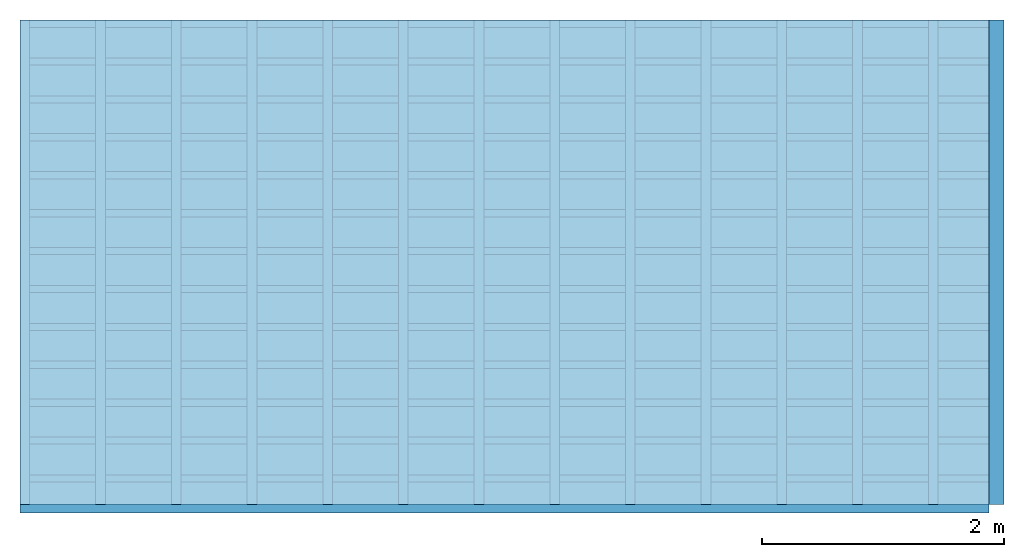
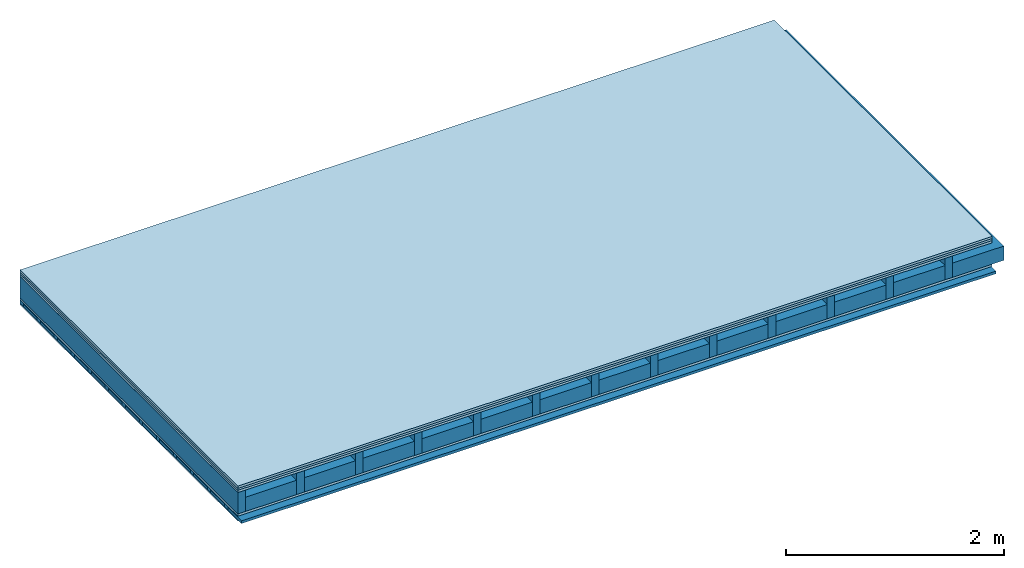
# One storey: 5 plates, 4 members, 1 element without a shape of its own.
"""IFC4 building model written with IfcOpenShell, lengths in metres."""

from ifc_helpers import new_model, si_unit, derived_unit, direction, frame, frame_2d, origin, origin_with_axes, place, context, project, spatial, rectangle, extrude, material, layer, layer_set, type_object, element, aggregate, save


model = new_model("IFC4")

# Units and contexts
plan_context = context("Plan", 3, precision=1e-05, world=origin(), true_north=direction((0.0, 1.0)))
model_context = context("Model", 3, precision=1e-05, world=origin(), true_north=direction((0.0, 1.0)))
ifc_project = project(units=[si_unit("LENGTHUNIT", "METRE"), derived_unit("SOUNDPRESSUREUNIT", [(si_unit("PRESSUREUNIT", "PASCAL", prefix="MICRO"), 0)]), si_unit("ENERGYUNIT", "JOULE", prefix="MEGA"), si_unit("MASSUNIT", "GRAM", prefix="KILO"), derived_unit("THERMALTRANSMITTANCEUNIT", [(si_unit("POWERUNIT", "WATT"), 1), (si_unit("AREAUNIT", "SQUARE_METRE"), -1), (si_unit("THERMODYNAMICTEMPERATUREUNIT", "KELVIN"), -1)]), derived_unit("AREADENSITYUNIT", [(si_unit("MASSUNIT", "GRAM", prefix="KILO"), 1), (si_unit("AREAUNIT", "SQUARE_METRE"), -1)]), derived_unit("USERDEFINED", [(si_unit("ENERGYUNIT", "JOULE", prefix="MEGA"), 1), (si_unit("AREAUNIT", "SQUARE_METRE"), -1)])], contexts=[plan_context, model_context])

# Site, building, storey
site = spatial("IfcSite", under=ifc_project)
building_placement = place(None, origin())
building = spatial("IfcBuilding", under=site, at=building_placement)
storey_placement = place(building_placement, origin())
storey = spatial("IfcBuildingStorey", under=building, at=storey_placement)

# Slab, members, plates
ifc_material_1 = material(Name="Floor heating system Therm38 longitudinal", Category="03.007")
ifc_layer_1 = layer(ifc_material_1, 0.025, Name="On-material")
ifc_material_2 = material(Category="10.009")
ifc_layer_2 = layer(ifc_material_2, 0.022, Name="Impact sound insulation")
ifc_material_3 = material(Category="07.001")
ifc_layer_3 = layer(ifc_material_3, 0.025, Name="Sub-floor")
ifc_material_4 = material(Name="Rigid, of the art")
ifc_layer_4 = layer(ifc_material_4, 0.0, Name="Bond")
ifc_layer_5 = layer(None, 0.24, Name="Supporting structure")
ifc_layer_6 = layer(ifc_material_4, 0.0, Name="Bond")
ifc_layer_7 = layer(ifc_material_3, 0.025, Name="Lower layer 1")
ifc_layer_8 = layer(None, 0.04, Name="Battens / profiles")
ifc_material_5 = material(Category="03.007")
ifc_layer_9 = layer(ifc_material_5, 0.015, Name="Ceiling covering 1st layer")
ifc_material_6 = material(Name="Glued joints")
ifc_layer_10 = layer(ifc_material_6, 0.0, Name="Surface / treatment")
ifc_layer_set = layer_set([ifc_layer_1, ifc_layer_2, ifc_layer_3, ifc_layer_4, ifc_layer_5, ifc_layer_6, ifc_layer_7, ifc_layer_8, ifc_layer_9, ifc_layer_10])
slab_type = type_object("IfcSlabType", Name="A0307", PredefinedType="NOTDEFINED", material=ifc_layer_set)
slab_placement = place(None, frame((0.0, 0.0, 0.0), z_axis=(0.0, 0.0, -1.0), x_axis=(1.0, 0.0, 0.0)))
slab = element("IfcSlab", 1, at=slab_placement, inside=storey, type_object=slab_type, material=ifc_layer_set, Name="Slab #1")
ifc_material_7 = material()
member_1_placement = place(slab_placement, origin())
member_1 = element("IfcMember", 2, at=member_1_placement, material=ifc_material_7, Name="Supporting structure", context=plan_context, shape_type="SweptSolid", body=[
    extrude(rectangle(XDim=0.08, YDim=0.24, at=frame_2d((0.04, 0.12), x_axis=(1.0, 0.0))), frame((0.0, 4.0, 0.072), z_axis=(0.0, -1.0, 0.0), x_axis=(1.0, 0.0, 0.0)), (0.0, 0.0, 1.0), 4.0),
    extrude(rectangle(XDim=0.08, YDim=0.24, at=frame_2d((0.04, 0.12), x_axis=(1.0, 0.0))), frame((0.625, 4.0, 0.072), z_axis=(0.0, -1.0, 0.0), x_axis=(1.0, 0.0, 0.0)), (0.0, 0.0, 1.0), 4.0),
    extrude(rectangle(XDim=0.08, YDim=0.24, at=frame_2d((0.04, 0.12), x_axis=(1.0, 0.0))), frame((1.25, 4.0, 0.072), z_axis=(0.0, -1.0, 0.0), x_axis=(1.0, 0.0, 0.0)), (0.0, 0.0, 1.0), 4.0),
    extrude(rectangle(XDim=0.08, YDim=0.24, at=frame_2d((0.04, 0.12), x_axis=(1.0, 0.0))), frame((1.875, 4.0, 0.072), z_axis=(0.0, -1.0, 0.0), x_axis=(1.0, 0.0, 0.0)), (0.0, 0.0, 1.0), 4.0),
    extrude(rectangle(XDim=0.08, YDim=0.24, at=frame_2d((0.04, 0.12), x_axis=(1.0, 0.0))), frame((2.5, 4.0, 0.072), z_axis=(0.0, -1.0, 0.0), x_axis=(1.0, 0.0, 0.0)), (0.0, 0.0, 1.0), 4.0),
    extrude(rectangle(XDim=0.08, YDim=0.24, at=frame_2d((0.04, 0.12), x_axis=(1.0, 0.0))), frame((3.125, 4.0, 0.072), z_axis=(0.0, -1.0, 0.0), x_axis=(1.0, 0.0, 0.0)), (0.0, 0.0, 1.0), 4.0),
    extrude(rectangle(XDim=0.08, YDim=0.24, at=frame_2d((0.04, 0.12), x_axis=(1.0, 0.0))), frame((3.75, 4.0, 0.072), z_axis=(0.0, -1.0, 0.0), x_axis=(1.0, 0.0, 0.0)), (0.0, 0.0, 1.0), 4.0),
    extrude(rectangle(XDim=0.08, YDim=0.24, at=frame_2d((0.04, 0.12), x_axis=(1.0, 0.0))), frame((4.375, 4.0, 0.072), z_axis=(0.0, -1.0, 0.0), x_axis=(1.0, 0.0, 0.0)), (0.0, 0.0, 1.0), 4.0),
    extrude(rectangle(XDim=0.08, YDim=0.24, at=frame_2d((0.04, 0.12), x_axis=(1.0, 0.0))), frame((5.0, 4.0, 0.072), z_axis=(0.0, -1.0, 0.0), x_axis=(1.0, 0.0, 0.0)), (0.0, 0.0, 1.0), 4.0),
    extrude(rectangle(XDim=0.08, YDim=0.24, at=frame_2d((0.04, 0.12), x_axis=(1.0, 0.0))), frame((5.625, 4.0, 0.072), z_axis=(0.0, -1.0, 0.0), x_axis=(1.0, 0.0, 0.0)), (0.0, 0.0, 1.0), 4.0),
    extrude(rectangle(XDim=0.08, YDim=0.24, at=frame_2d((0.04, 0.12), x_axis=(1.0, 0.0))), frame((6.25, 4.0, 0.072), z_axis=(0.0, -1.0, 0.0), x_axis=(1.0, 0.0, 0.0)), (0.0, 0.0, 1.0), 4.0),
    extrude(rectangle(XDim=0.08, YDim=0.24, at=frame_2d((0.04, 0.12), x_axis=(1.0, 0.0))), frame((6.875, 4.0, 0.072), z_axis=(0.0, -1.0, 0.0), x_axis=(1.0, 0.0, 0.0)), (0.0, 0.0, 1.0), 4.0),
    extrude(rectangle(XDim=0.08, YDim=0.24, at=frame_2d((0.04, 0.12), x_axis=(1.0, 0.0))), frame((7.5, 4.0, 0.072), z_axis=(0.0, -1.0, 0.0), x_axis=(1.0, 0.0, 0.0)), (0.0, 0.0, 1.0), 4.0),
])
ifc_material_8 = material()
member_2_placement = place(slab_placement, origin())
member_2 = element("IfcMember", 3, at=member_2_placement, material=ifc_material_8, Name="Cavity", context=plan_context, shape_type="SweptSolid", body=[
    extrude(rectangle(XDim=0.545, YDim=0.16, at=frame_2d((0.2725, 0.08), x_axis=(1.0, 0.0))), frame((0.08, 4.0, 0.152), z_axis=(0.0, -1.0, 0.0), x_axis=(1.0, 0.0, 0.0)), (0.0, 0.0, 1.0), 4.0),
    extrude(rectangle(XDim=0.545, YDim=0.16, at=frame_2d((0.2725, 0.08), x_axis=(1.0, 0.0))), frame((0.705, 4.0, 0.152), z_axis=(0.0, -1.0, 0.0), x_axis=(1.0, 0.0, 0.0)), (0.0, 0.0, 1.0), 4.0),
    extrude(rectangle(XDim=0.545, YDim=0.16, at=frame_2d((0.2725, 0.08), x_axis=(1.0, 0.0))), frame((1.33, 4.0, 0.152), z_axis=(0.0, -1.0, 0.0), x_axis=(1.0, 0.0, 0.0)), (0.0, 0.0, 1.0), 4.0),
    extrude(rectangle(XDim=0.545, YDim=0.16, at=frame_2d((0.2725, 0.08), x_axis=(1.0, 0.0))), frame((1.955, 4.0, 0.152), z_axis=(0.0, -1.0, 0.0), x_axis=(1.0, 0.0, 0.0)), (0.0, 0.0, 1.0), 4.0),
    extrude(rectangle(XDim=0.545, YDim=0.16, at=frame_2d((0.2725, 0.08), x_axis=(1.0, 0.0))), frame((2.58, 4.0, 0.152), z_axis=(0.0, -1.0, 0.0), x_axis=(1.0, 0.0, 0.0)), (0.0, 0.0, 1.0), 4.0),
    extrude(rectangle(XDim=0.545, YDim=0.16, at=frame_2d((0.2725, 0.08), x_axis=(1.0, 0.0))), frame((3.205, 4.0, 0.152), z_axis=(0.0, -1.0, 0.0), x_axis=(1.0, 0.0, 0.0)), (0.0, 0.0, 1.0), 4.0),
    extrude(rectangle(XDim=0.545, YDim=0.16, at=frame_2d((0.2725, 0.08), x_axis=(1.0, 0.0))), frame((3.83, 4.0, 0.152), z_axis=(0.0, -1.0, 0.0), x_axis=(1.0, 0.0, 0.0)), (0.0, 0.0, 1.0), 4.0),
    extrude(rectangle(XDim=0.545, YDim=0.16, at=frame_2d((0.2725, 0.08), x_axis=(1.0, 0.0))), frame((4.455, 4.0, 0.152), z_axis=(0.0, -1.0, 0.0), x_axis=(1.0, 0.0, 0.0)), (0.0, 0.0, 1.0), 4.0),
    extrude(rectangle(XDim=0.545, YDim=0.16, at=frame_2d((0.2725, 0.08), x_axis=(1.0, 0.0))), frame((5.08, 4.0, 0.152), z_axis=(0.0, -1.0, 0.0), x_axis=(1.0, 0.0, 0.0)), (0.0, 0.0, 1.0), 4.0),
    extrude(rectangle(XDim=0.545, YDim=0.16, at=frame_2d((0.2725, 0.08), x_axis=(1.0, 0.0))), frame((5.705, 4.0, 0.152), z_axis=(0.0, -1.0, 0.0), x_axis=(1.0, 0.0, 0.0)), (0.0, 0.0, 1.0), 4.0),
    extrude(rectangle(XDim=0.545, YDim=0.16, at=frame_2d((0.2725, 0.08), x_axis=(1.0, 0.0))), frame((6.33, 4.0, 0.152), z_axis=(0.0, -1.0, 0.0), x_axis=(1.0, 0.0, 0.0)), (0.0, 0.0, 1.0), 4.0),
    extrude(rectangle(XDim=0.545, YDim=0.16, at=frame_2d((0.2725, 0.08), x_axis=(1.0, 0.0))), frame((6.955, 4.0, 0.152), z_axis=(0.0, -1.0, 0.0), x_axis=(1.0, 0.0, 0.0)), (0.0, 0.0, 1.0), 4.0),
    extrude(rectangle(XDim=0.545, YDim=0.16, at=frame_2d((0.2725, 0.08), x_axis=(1.0, 0.0))), frame((7.58, 4.0, 0.152), z_axis=(0.0, -1.0, 0.0), x_axis=(1.0, 0.0, 0.0)), (0.0, 0.0, 1.0), 4.0),
])
ifc_material_9 = material()
member_3_placement = place(slab_placement, origin())
member_3 = element("IfcMember", 4, at=member_3_placement, material=ifc_material_9, Name="Battens / profiles", context=plan_context, shape_type="SweptSolid", body=[
    extrude(rectangle(XDim=0.06, YDim=0.04, at=frame_2d((0.03, 0.02), x_axis=(1.0, 0.0))), frame((0.0, 0.0, 0.337), z_axis=(1.0, 0.0, 0.0), x_axis=(0.0, 1.0, 0.0)), (0.0, 0.0, 1.0), 8.0),
    extrude(rectangle(XDim=0.06, YDim=0.04, at=frame_2d((0.03, 0.02), x_axis=(1.0, 0.0))), frame((0.0, 0.313, 0.337), z_axis=(1.0, 0.0, 0.0), x_axis=(0.0, 1.0, 0.0)), (0.0, 0.0, 1.0), 8.0),
    extrude(rectangle(XDim=0.06, YDim=0.04, at=frame_2d((0.03, 0.02), x_axis=(1.0, 0.0))), frame((0.0, 0.626, 0.337), z_axis=(1.0, 0.0, 0.0), x_axis=(0.0, 1.0, 0.0)), (0.0, 0.0, 1.0), 8.0),
    extrude(rectangle(XDim=0.06, YDim=0.04, at=frame_2d((0.03, 0.02), x_axis=(1.0, 0.0))), frame((0.0, 0.939, 0.337), z_axis=(1.0, 0.0, 0.0), x_axis=(0.0, 1.0, 0.0)), (0.0, 0.0, 1.0), 8.0),
    extrude(rectangle(XDim=0.06, YDim=0.04, at=frame_2d((0.03, 0.02), x_axis=(1.0, 0.0))), frame((0.0, 1.252, 0.337), z_axis=(1.0, 0.0, 0.0), x_axis=(0.0, 1.0, 0.0)), (0.0, 0.0, 1.0), 8.0),
    extrude(rectangle(XDim=0.06, YDim=0.04, at=frame_2d((0.03, 0.02), x_axis=(1.0, 0.0))), frame((0.0, 1.565, 0.337), z_axis=(1.0, 0.0, 0.0), x_axis=(0.0, 1.0, 0.0)), (0.0, 0.0, 1.0), 8.0),
    extrude(rectangle(XDim=0.06, YDim=0.04, at=frame_2d((0.03, 0.02), x_axis=(1.0, 0.0))), frame((0.0, 1.878, 0.337), z_axis=(1.0, 0.0, 0.0), x_axis=(0.0, 1.0, 0.0)), (0.0, 0.0, 1.0), 8.0),
    extrude(rectangle(XDim=0.06, YDim=0.04, at=frame_2d((0.03, 0.02), x_axis=(1.0, 0.0))), frame((0.0, 2.191, 0.337), z_axis=(1.0, 0.0, 0.0), x_axis=(0.0, 1.0, 0.0)), (0.0, 0.0, 1.0), 8.0),
    extrude(rectangle(XDim=0.06, YDim=0.04, at=frame_2d((0.03, 0.02), x_axis=(1.0, 0.0))), frame((0.0, 2.504, 0.337), z_axis=(1.0, 0.0, 0.0), x_axis=(0.0, 1.0, 0.0)), (0.0, 0.0, 1.0), 8.0),
    extrude(rectangle(XDim=0.06, YDim=0.04, at=frame_2d((0.03, 0.02), x_axis=(1.0, 0.0))), frame((0.0, 2.817, 0.337), z_axis=(1.0, 0.0, 0.0), x_axis=(0.0, 1.0, 0.0)), (0.0, 0.0, 1.0), 8.0),
    extrude(rectangle(XDim=0.06, YDim=0.04, at=frame_2d((0.03, 0.02), x_axis=(1.0, 0.0))), frame((0.0, 3.13, 0.337), z_axis=(1.0, 0.0, 0.0), x_axis=(0.0, 1.0, 0.0)), (0.0, 0.0, 1.0), 8.0),
    extrude(rectangle(XDim=0.06, YDim=0.04, at=frame_2d((0.03, 0.02), x_axis=(1.0, 0.0))), frame((0.0, 3.443, 0.337), z_axis=(1.0, 0.0, 0.0), x_axis=(0.0, 1.0, 0.0)), (0.0, 0.0, 1.0), 8.0),
    extrude(rectangle(XDim=0.06, YDim=0.04, at=frame_2d((0.03, 0.02), x_axis=(1.0, 0.0))), frame((0.0, 3.756, 0.337), z_axis=(1.0, 0.0, 0.0), x_axis=(0.0, 1.0, 0.0)), (0.0, 0.0, 1.0), 8.0),
])
member_4_placement = place(slab_placement, origin())
member_4 = element("IfcMember", 5, at=member_4_placement, material=ifc_material_8, Name="Cavity", context=plan_context, shape_type="SweptSolid", body=[
    extrude(rectangle(XDim=0.253, YDim=0.03, at=frame_2d((0.1265, 0.015), x_axis=(1.0, 0.0))), frame((0.0, 0.06, 0.347), z_axis=(1.0, 0.0, 0.0), x_axis=(0.0, 1.0, 0.0)), (0.0, 0.0, 1.0), 8.0),
    extrude(rectangle(XDim=0.253, YDim=0.03, at=frame_2d((0.1265, 0.015), x_axis=(1.0, 0.0))), frame((0.0, 0.373, 0.347), z_axis=(1.0, 0.0, 0.0), x_axis=(0.0, 1.0, 0.0)), (0.0, 0.0, 1.0), 8.0),
    extrude(rectangle(XDim=0.253, YDim=0.03, at=frame_2d((0.1265, 0.015), x_axis=(1.0, 0.0))), frame((0.0, 0.686, 0.347), z_axis=(1.0, 0.0, 0.0), x_axis=(0.0, 1.0, 0.0)), (0.0, 0.0, 1.0), 8.0),
    extrude(rectangle(XDim=0.253, YDim=0.03, at=frame_2d((0.1265, 0.015), x_axis=(1.0, 0.0))), frame((0.0, 0.999, 0.347), z_axis=(1.0, 0.0, 0.0), x_axis=(0.0, 1.0, 0.0)), (0.0, 0.0, 1.0), 8.0),
    extrude(rectangle(XDim=0.253, YDim=0.03, at=frame_2d((0.1265, 0.015), x_axis=(1.0, 0.0))), frame((0.0, 1.312, 0.347), z_axis=(1.0, 0.0, 0.0), x_axis=(0.0, 1.0, 0.0)), (0.0, 0.0, 1.0), 8.0),
    extrude(rectangle(XDim=0.253, YDim=0.03, at=frame_2d((0.1265, 0.015), x_axis=(1.0, 0.0))), frame((0.0, 1.625, 0.347), z_axis=(1.0, 0.0, 0.0), x_axis=(0.0, 1.0, 0.0)), (0.0, 0.0, 1.0), 8.0),
    extrude(rectangle(XDim=0.253, YDim=0.03, at=frame_2d((0.1265, 0.015), x_axis=(1.0, 0.0))), frame((0.0, 1.938, 0.347), z_axis=(1.0, 0.0, 0.0), x_axis=(0.0, 1.0, 0.0)), (0.0, 0.0, 1.0), 8.0),
    extrude(rectangle(XDim=0.253, YDim=0.03, at=frame_2d((0.1265, 0.015), x_axis=(1.0, 0.0))), frame((0.0, 2.251, 0.347), z_axis=(1.0, 0.0, 0.0), x_axis=(0.0, 1.0, 0.0)), (0.0, 0.0, 1.0), 8.0),
    extrude(rectangle(XDim=0.253, YDim=0.03, at=frame_2d((0.1265, 0.015), x_axis=(1.0, 0.0))), frame((0.0, 2.564, 0.347), z_axis=(1.0, 0.0, 0.0), x_axis=(0.0, 1.0, 0.0)), (0.0, 0.0, 1.0), 8.0),
    extrude(rectangle(XDim=0.253, YDim=0.03, at=frame_2d((0.1265, 0.015), x_axis=(1.0, 0.0))), frame((0.0, 2.877, 0.347), z_axis=(1.0, 0.0, 0.0), x_axis=(0.0, 1.0, 0.0)), (0.0, 0.0, 1.0), 8.0),
    extrude(rectangle(XDim=0.253, YDim=0.03, at=frame_2d((0.1265, 0.015), x_axis=(1.0, 0.0))), frame((0.0, 3.19, 0.347), z_axis=(1.0, 0.0, 0.0), x_axis=(0.0, 1.0, 0.0)), (0.0, 0.0, 1.0), 8.0),
    extrude(rectangle(XDim=0.253, YDim=0.03, at=frame_2d((0.1265, 0.015), x_axis=(1.0, 0.0))), frame((0.0, 3.503, 0.347), z_axis=(1.0, 0.0, 0.0), x_axis=(0.0, 1.0, 0.0)), (0.0, 0.0, 1.0), 8.0),
    extrude(rectangle(XDim=0.253, YDim=0.03, at=frame_2d((0.1265, 0.015), x_axis=(1.0, 0.0))), frame((0.0, 3.816, 0.347), z_axis=(1.0, 0.0, 0.0), x_axis=(0.0, 1.0, 0.0)), (0.0, 0.0, 1.0), 8.0),
])
plate_1_placement = place(slab_placement, origin())
plate_1 = element("IfcPlate", 6, at=plate_1_placement, material=ifc_material_1, Name="On-material", context=plan_context, shape_type="SweptSolid", body=[
    extrude(rectangle(XDim=8.0, YDim=4.0, at=frame_2d((4.0, 2.0), x_axis=(1.0, 0.0))), origin_with_axes(), (0.0, 0.0, 1.0), 0.025),
])
plate_2_placement = place(slab_placement, origin())
plate_2 = element("IfcPlate", 7, at=plate_2_placement, material=ifc_material_2, Name="Impact sound insulation", context=plan_context, shape_type="SweptSolid", body=[
    extrude(rectangle(XDim=8.0, YDim=4.0, at=frame_2d((4.0, 2.0), x_axis=(1.0, 0.0))), frame((0.0, 0.0, 0.025), z_axis=(0.0, 0.0, 1.0), x_axis=(1.0, 0.0, 0.0)), (0.0, 0.0, 1.0), 0.022),
])
plate_3_placement = place(slab_placement, origin())
plate_3 = element("IfcPlate", 8, at=plate_3_placement, material=ifc_material_3, Name="Sub-floor", context=plan_context, shape_type="SweptSolid", body=[
    extrude(rectangle(XDim=8.0, YDim=4.0, at=frame_2d((4.0, 2.0), x_axis=(1.0, 0.0))), frame((0.0, 0.0, 0.047), z_axis=(0.0, 0.0, 1.0), x_axis=(1.0, 0.0, 0.0)), (0.0, 0.0, 1.0), 0.025),
])
plate_4_placement = place(slab_placement, origin())
plate_4 = element("IfcPlate", 9, at=plate_4_placement, material=ifc_material_3, Name="Lower layer 1", context=plan_context, shape_type="SweptSolid", body=[
    extrude(rectangle(XDim=8.0, YDim=4.0, at=frame_2d((4.0, 2.0), x_axis=(1.0, 0.0))), frame((0.0, 0.0, 0.312), z_axis=(0.0, 0.0, 1.0), x_axis=(1.0, 0.0, 0.0)), (0.0, 0.0, 1.0), 0.025),
])
plate_5_placement = place(slab_placement, origin())
plate_5 = element("IfcPlate", 10, at=plate_5_placement, material=ifc_material_5, Name="Ceiling covering 1st layer", context=plan_context, shape_type="SweptSolid", body=[
    extrude(rectangle(XDim=8.0, YDim=4.0, at=frame_2d((4.0, 2.0), x_axis=(1.0, 0.0))), frame((0.0, 0.0, 0.377), z_axis=(0.0, 0.0, 1.0), x_axis=(1.0, 0.0, 0.0)), (0.0, 0.0, 1.0), 0.015),
])
aggregate(slab, [plate_1, plate_2, plate_3, member_1, member_2, plate_4, member_3, member_4, plate_5])

save(model, "model.ifc")
